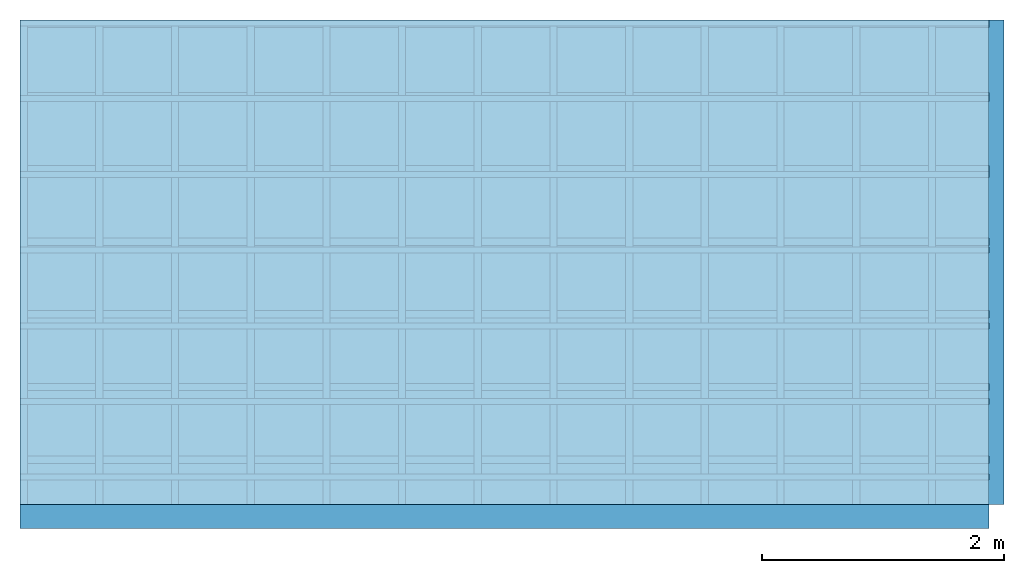
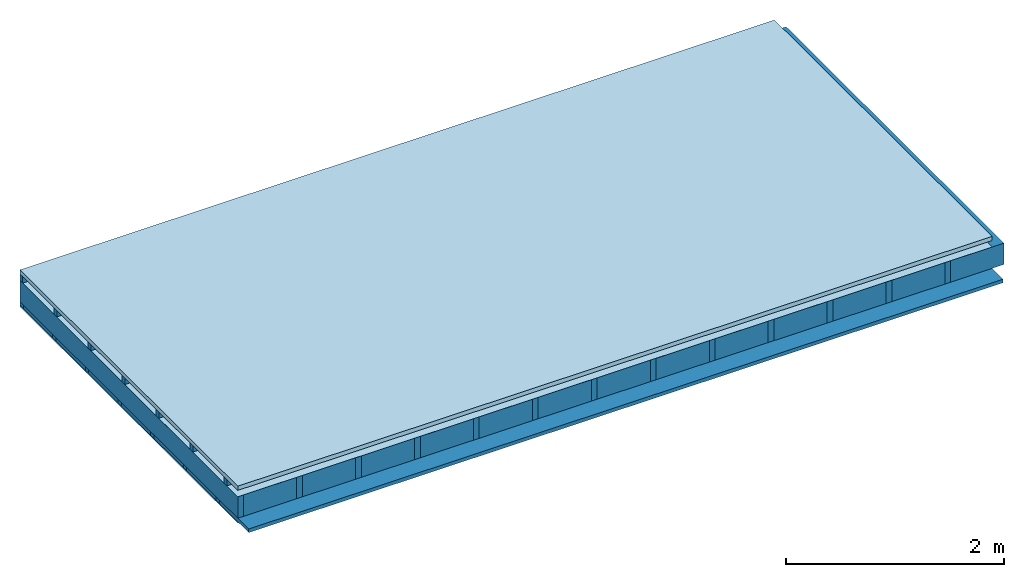
# One storey: 5 members, 3 plates, 1 element without a shape of its own.
"""IFC4 building model written with IfcOpenShell, lengths in metres."""

from ifc_helpers import new_model, si_unit, derived_unit, direction, frame, frame_2d, origin, origin_with_axes, place, context, project, spatial, rectangle, extrude, material, layer, layer_set, type_object, element, aggregate, save


model = new_model("IFC4")

# Units and contexts
plan_context = context("Plan", 3, precision=1e-05, world=origin(), true_north=direction((0.0, 1.0)))
model_context = context("Model", 3, precision=1e-05, world=origin(), true_north=direction((0.0, 1.0)))
ifc_project = project(units=[si_unit("LENGTHUNIT", "METRE"), derived_unit("SOUNDPRESSUREUNIT", [(si_unit("PRESSUREUNIT", "PASCAL", prefix="MICRO"), 0)]), si_unit("ENERGYUNIT", "JOULE", prefix="MEGA"), si_unit("MASSUNIT", "GRAM", prefix="KILO"), derived_unit("THERMALTRANSMITTANCEUNIT", [(si_unit("POWERUNIT", "WATT"), 1), (si_unit("AREAUNIT", "SQUARE_METRE"), -1), (si_unit("THERMODYNAMICTEMPERATUREUNIT", "KELVIN"), -1)]), derived_unit("AREADENSITYUNIT", [(si_unit("MASSUNIT", "GRAM", prefix="KILO"), 1), (si_unit("AREAUNIT", "SQUARE_METRE"), -1)]), derived_unit("USERDEFINED", [(si_unit("ENERGYUNIT", "JOULE", prefix="MEGA"), 1), (si_unit("AREAUNIT", "SQUARE_METRE"), -1)])], contexts=[plan_context, model_context])

# Site, building, storey
site = spatial("IfcSite", under=ifc_project)
building_placement = place(None, origin())
building = spatial("IfcBuilding", under=site, at=building_placement)
storey_placement = place(building_placement, origin())
storey = spatial("IfcBuildingStorey", under=building, at=storey_placement)

# Slab, members, plates
ifc_material_1 = material(Name="Roof tiles", Category="03.015")
ifc_layer_1 = layer(ifc_material_1, 0.047, Name="Roofing")
ifc_layer_2 = layer(None, 0.072, Name="Battens / profiles")
ifc_material_2 = material(Name="Roofing underlay", Category="09.008")
ifc_layer_3 = layer(ifc_material_2, 0.00018, Name="Under the roof")
ifc_material_3 = material(Name="no composite action")
ifc_layer_4 = layer(ifc_material_3, 0.0, Name="Bond")
ifc_layer_5 = layer(None, 0.24, Name="Supporting structure")
ifc_material_4 = material(Name="of the art")
ifc_layer_6 = layer(ifc_material_4, 0.0, Name="Bond")
ifc_layer_7 = layer(None, 0.04, Name="Battens / profiles")
ifc_material_5 = material(Name="Plasterboard type A", Category="03.008")
ifc_layer_8 = layer(ifc_material_5, 0.015, Name="Covering below 1st layer")
ifc_material_6 = material(Name="joints", Category="04.017")
ifc_layer_9 = layer(ifc_material_6, 0.0, Name="Surface below")
ifc_layer_set = layer_set([ifc_layer_1, ifc_layer_2, ifc_layer_3, ifc_layer_4, ifc_layer_5, ifc_layer_6, ifc_layer_7, ifc_layer_8, ifc_layer_9])
slab_type = type_object("IfcSlabType", Name="E0073", PredefinedType="NOTDEFINED", material=ifc_layer_set)
slab_placement = place(None, frame((0.0, 0.0, 0.0), z_axis=(0.0, 0.0, -1.0), x_axis=(1.0, 0.0, 0.0)))
slab = element("IfcSlab", 1, at=slab_placement, inside=storey, type_object=slab_type, material=ifc_layer_set, Name="Slab #1")
ifc_material_7 = material()
member_1_placement = place(slab_placement, origin())
member_1 = element("IfcMember", 2, at=member_1_placement, material=ifc_material_7, Name="Battens / profiles", context=plan_context, shape_type="SweptSolid", body=[
    extrude(rectangle(XDim=0.05, YDim=0.072, at=frame_2d((0.025, 0.036), x_axis=(1.0, 0.0))), frame((0.0, 0.0, 0.047), z_axis=(1.0, 0.0, 0.0), x_axis=(0.0, 1.0, 0.0)), (0.0, 0.0, 1.0), 8.0),
    extrude(rectangle(XDim=0.05, YDim=0.072, at=frame_2d((0.025, 0.036), x_axis=(1.0, 0.0))), frame((0.0, 0.625, 0.047), z_axis=(1.0, 0.0, 0.0), x_axis=(0.0, 1.0, 0.0)), (0.0, 0.0, 1.0), 8.0),
    extrude(rectangle(XDim=0.05, YDim=0.072, at=frame_2d((0.025, 0.036), x_axis=(1.0, 0.0))), frame((0.0, 1.25, 0.047), z_axis=(1.0, 0.0, 0.0), x_axis=(0.0, 1.0, 0.0)), (0.0, 0.0, 1.0), 8.0),
    extrude(rectangle(XDim=0.05, YDim=0.072, at=frame_2d((0.025, 0.036), x_axis=(1.0, 0.0))), frame((0.0, 1.875, 0.047), z_axis=(1.0, 0.0, 0.0), x_axis=(0.0, 1.0, 0.0)), (0.0, 0.0, 1.0), 8.0),
    extrude(rectangle(XDim=0.05, YDim=0.072, at=frame_2d((0.025, 0.036), x_axis=(1.0, 0.0))), frame((0.0, 2.5, 0.047), z_axis=(1.0, 0.0, 0.0), x_axis=(0.0, 1.0, 0.0)), (0.0, 0.0, 1.0), 8.0),
    extrude(rectangle(XDim=0.05, YDim=0.072, at=frame_2d((0.025, 0.036), x_axis=(1.0, 0.0))), frame((0.0, 3.125, 0.047), z_axis=(1.0, 0.0, 0.0), x_axis=(0.0, 1.0, 0.0)), (0.0, 0.0, 1.0), 8.0),
    extrude(rectangle(XDim=0.05, YDim=0.072, at=frame_2d((0.025, 0.036), x_axis=(1.0, 0.0))), frame((0.0, 3.75, 0.047), z_axis=(1.0, 0.0, 0.0), x_axis=(0.0, 1.0, 0.0)), (0.0, 0.0, 1.0), 8.0),
])
ifc_material_8 = material()
member_2_placement = place(slab_placement, origin())
member_2 = element("IfcMember", 3, at=member_2_placement, material=ifc_material_8, Name="Supporting structure", context=plan_context, shape_type="SweptSolid", body=[
    extrude(rectangle(XDim=0.06, YDim=0.24, at=frame_2d((0.03, 0.12), x_axis=(1.0, 0.0))), frame((0.0, 4.0, 0.11918), z_axis=(0.0, -1.0, 0.0), x_axis=(1.0, 0.0, 0.0)), (0.0, 0.0, 1.0), 4.0),
    extrude(rectangle(XDim=0.06, YDim=0.24, at=frame_2d((0.03, 0.12), x_axis=(1.0, 0.0))), frame((0.625, 4.0, 0.11918), z_axis=(0.0, -1.0, 0.0), x_axis=(1.0, 0.0, 0.0)), (0.0, 0.0, 1.0), 4.0),
    extrude(rectangle(XDim=0.06, YDim=0.24, at=frame_2d((0.03, 0.12), x_axis=(1.0, 0.0))), frame((1.25, 4.0, 0.11918), z_axis=(0.0, -1.0, 0.0), x_axis=(1.0, 0.0, 0.0)), (0.0, 0.0, 1.0), 4.0),
    extrude(rectangle(XDim=0.06, YDim=0.24, at=frame_2d((0.03, 0.12), x_axis=(1.0, 0.0))), frame((1.875, 4.0, 0.11918), z_axis=(0.0, -1.0, 0.0), x_axis=(1.0, 0.0, 0.0)), (0.0, 0.0, 1.0), 4.0),
    extrude(rectangle(XDim=0.06, YDim=0.24, at=frame_2d((0.03, 0.12), x_axis=(1.0, 0.0))), frame((2.5, 4.0, 0.11918), z_axis=(0.0, -1.0, 0.0), x_axis=(1.0, 0.0, 0.0)), (0.0, 0.0, 1.0), 4.0),
    extrude(rectangle(XDim=0.06, YDim=0.24, at=frame_2d((0.03, 0.12), x_axis=(1.0, 0.0))), frame((3.125, 4.0, 0.11918), z_axis=(0.0, -1.0, 0.0), x_axis=(1.0, 0.0, 0.0)), (0.0, 0.0, 1.0), 4.0),
    extrude(rectangle(XDim=0.06, YDim=0.24, at=frame_2d((0.03, 0.12), x_axis=(1.0, 0.0))), frame((3.75, 4.0, 0.11918), z_axis=(0.0, -1.0, 0.0), x_axis=(1.0, 0.0, 0.0)), (0.0, 0.0, 1.0), 4.0),
    extrude(rectangle(XDim=0.06, YDim=0.24, at=frame_2d((0.03, 0.12), x_axis=(1.0, 0.0))), frame((4.375, 4.0, 0.11918), z_axis=(0.0, -1.0, 0.0), x_axis=(1.0, 0.0, 0.0)), (0.0, 0.0, 1.0), 4.0),
    extrude(rectangle(XDim=0.06, YDim=0.24, at=frame_2d((0.03, 0.12), x_axis=(1.0, 0.0))), frame((5.0, 4.0, 0.11918), z_axis=(0.0, -1.0, 0.0), x_axis=(1.0, 0.0, 0.0)), (0.0, 0.0, 1.0), 4.0),
    extrude(rectangle(XDim=0.06, YDim=0.24, at=frame_2d((0.03, 0.12), x_axis=(1.0, 0.0))), frame((5.625, 4.0, 0.11918), z_axis=(0.0, -1.0, 0.0), x_axis=(1.0, 0.0, 0.0)), (0.0, 0.0, 1.0), 4.0),
    extrude(rectangle(XDim=0.06, YDim=0.24, at=frame_2d((0.03, 0.12), x_axis=(1.0, 0.0))), frame((6.25, 4.0, 0.11918), z_axis=(0.0, -1.0, 0.0), x_axis=(1.0, 0.0, 0.0)), (0.0, 0.0, 1.0), 4.0),
    extrude(rectangle(XDim=0.06, YDim=0.24, at=frame_2d((0.03, 0.12), x_axis=(1.0, 0.0))), frame((6.875, 4.0, 0.11918), z_axis=(0.0, -1.0, 0.0), x_axis=(1.0, 0.0, 0.0)), (0.0, 0.0, 1.0), 4.0),
    extrude(rectangle(XDim=0.06, YDim=0.24, at=frame_2d((0.03, 0.12), x_axis=(1.0, 0.0))), frame((7.5, 4.0, 0.11918), z_axis=(0.0, -1.0, 0.0), x_axis=(1.0, 0.0, 0.0)), (0.0, 0.0, 1.0), 4.0),
])
ifc_material_9 = material()
member_3_placement = place(slab_placement, origin())
member_3 = element("IfcMember", 4, at=member_3_placement, material=ifc_material_9, Name="Cavity", context=plan_context, shape_type="SweptSolid", body=[
    extrude(rectangle(XDim=0.565, YDim=0.24, at=frame_2d((0.2825, 0.12), x_axis=(1.0, 0.0))), frame((0.06, 4.0, 0.11918), z_axis=(0.0, -1.0, 0.0), x_axis=(1.0, 0.0, 0.0)), (0.0, 0.0, 1.0), 4.0),
    extrude(rectangle(XDim=0.565, YDim=0.24, at=frame_2d((0.2825, 0.12), x_axis=(1.0, 0.0))), frame((0.685, 4.0, 0.11918), z_axis=(0.0, -1.0, 0.0), x_axis=(1.0, 0.0, 0.0)), (0.0, 0.0, 1.0), 4.0),
    extrude(rectangle(XDim=0.565, YDim=0.24, at=frame_2d((0.2825, 0.12), x_axis=(1.0, 0.0))), frame((1.31, 4.0, 0.11918), z_axis=(0.0, -1.0, 0.0), x_axis=(1.0, 0.0, 0.0)), (0.0, 0.0, 1.0), 4.0),
    extrude(rectangle(XDim=0.565, YDim=0.24, at=frame_2d((0.2825, 0.12), x_axis=(1.0, 0.0))), frame((1.935, 4.0, 0.11918), z_axis=(0.0, -1.0, 0.0), x_axis=(1.0, 0.0, 0.0)), (0.0, 0.0, 1.0), 4.0),
    extrude(rectangle(XDim=0.565, YDim=0.24, at=frame_2d((0.2825, 0.12), x_axis=(1.0, 0.0))), frame((2.56, 4.0, 0.11918), z_axis=(0.0, -1.0, 0.0), x_axis=(1.0, 0.0, 0.0)), (0.0, 0.0, 1.0), 4.0),
    extrude(rectangle(XDim=0.565, YDim=0.24, at=frame_2d((0.2825, 0.12), x_axis=(1.0, 0.0))), frame((3.185, 4.0, 0.11918), z_axis=(0.0, -1.0, 0.0), x_axis=(1.0, 0.0, 0.0)), (0.0, 0.0, 1.0), 4.0),
    extrude(rectangle(XDim=0.565, YDim=0.24, at=frame_2d((0.2825, 0.12), x_axis=(1.0, 0.0))), frame((3.81, 4.0, 0.11918), z_axis=(0.0, -1.0, 0.0), x_axis=(1.0, 0.0, 0.0)), (0.0, 0.0, 1.0), 4.0),
    extrude(rectangle(XDim=0.565, YDim=0.24, at=frame_2d((0.2825, 0.12), x_axis=(1.0, 0.0))), frame((4.435, 4.0, 0.11918), z_axis=(0.0, -1.0, 0.0), x_axis=(1.0, 0.0, 0.0)), (0.0, 0.0, 1.0), 4.0),
    extrude(rectangle(XDim=0.565, YDim=0.24, at=frame_2d((0.2825, 0.12), x_axis=(1.0, 0.0))), frame((5.06, 4.0, 0.11918), z_axis=(0.0, -1.0, 0.0), x_axis=(1.0, 0.0, 0.0)), (0.0, 0.0, 1.0), 4.0),
    extrude(rectangle(XDim=0.565, YDim=0.24, at=frame_2d((0.2825, 0.12), x_axis=(1.0, 0.0))), frame((5.685, 4.0, 0.11918), z_axis=(0.0, -1.0, 0.0), x_axis=(1.0, 0.0, 0.0)), (0.0, 0.0, 1.0), 4.0),
    extrude(rectangle(XDim=0.565, YDim=0.24, at=frame_2d((0.2825, 0.12), x_axis=(1.0, 0.0))), frame((6.31, 4.0, 0.11918), z_axis=(0.0, -1.0, 0.0), x_axis=(1.0, 0.0, 0.0)), (0.0, 0.0, 1.0), 4.0),
    extrude(rectangle(XDim=0.565, YDim=0.24, at=frame_2d((0.2825, 0.12), x_axis=(1.0, 0.0))), frame((6.935, 4.0, 0.11918), z_axis=(0.0, -1.0, 0.0), x_axis=(1.0, 0.0, 0.0)), (0.0, 0.0, 1.0), 4.0),
    extrude(rectangle(XDim=0.565, YDim=0.24, at=frame_2d((0.2825, 0.12), x_axis=(1.0, 0.0))), frame((7.56, 4.0, 0.11918), z_axis=(0.0, -1.0, 0.0), x_axis=(1.0, 0.0, 0.0)), (0.0, 0.0, 1.0), 4.0),
])
ifc_material_10 = material()
member_4_placement = place(slab_placement, origin())
member_4 = element("IfcMember", 5, at=member_4_placement, material=ifc_material_10, Name="Battens / profiles", context=plan_context, shape_type="SweptSolid", body=[
    extrude(rectangle(XDim=0.06, YDim=0.04, at=frame_2d((0.03, 0.02), x_axis=(1.0, 0.0))), frame((0.0, 0.0, 0.35918), z_axis=(1.0, 0.0, 0.0), x_axis=(0.0, 1.0, 0.0)), (0.0, 0.0, 1.0), 8.0),
    extrude(rectangle(XDim=0.06, YDim=0.04, at=frame_2d((0.03, 0.02), x_axis=(1.0, 0.0))), frame((0.0, 0.6, 0.35918), z_axis=(1.0, 0.0, 0.0), x_axis=(0.0, 1.0, 0.0)), (0.0, 0.0, 1.0), 8.0),
    extrude(rectangle(XDim=0.06, YDim=0.04, at=frame_2d((0.03, 0.02), x_axis=(1.0, 0.0))), frame((0.0, 1.2, 0.35918), z_axis=(1.0, 0.0, 0.0), x_axis=(0.0, 1.0, 0.0)), (0.0, 0.0, 1.0), 8.0),
    extrude(rectangle(XDim=0.06, YDim=0.04, at=frame_2d((0.03, 0.02), x_axis=(1.0, 0.0))), frame((0.0, 1.8, 0.35918), z_axis=(1.0, 0.0, 0.0), x_axis=(0.0, 1.0, 0.0)), (0.0, 0.0, 1.0), 8.0),
    extrude(rectangle(XDim=0.06, YDim=0.04, at=frame_2d((0.03, 0.02), x_axis=(1.0, 0.0))), frame((0.0, 2.4, 0.35918), z_axis=(1.0, 0.0, 0.0), x_axis=(0.0, 1.0, 0.0)), (0.0, 0.0, 1.0), 8.0),
    extrude(rectangle(XDim=0.06, YDim=0.04, at=frame_2d((0.03, 0.02), x_axis=(1.0, 0.0))), frame((0.0, 3.0, 0.35918), z_axis=(1.0, 0.0, 0.0), x_axis=(0.0, 1.0, 0.0)), (0.0, 0.0, 1.0), 8.0),
    extrude(rectangle(XDim=0.06, YDim=0.04, at=frame_2d((0.03, 0.02), x_axis=(1.0, 0.0))), frame((0.0, 3.6, 0.35918), z_axis=(1.0, 0.0, 0.0), x_axis=(0.0, 1.0, 0.0)), (0.0, 0.0, 1.0), 8.0),
])
ifc_material_11 = material(Name="Mineral wool")
member_5_placement = place(slab_placement, origin())
member_5 = element("IfcMember", 6, at=member_5_placement, material=ifc_material_11, Name="Cavity", context=plan_context, shape_type="SweptSolid", body=[
    extrude(rectangle(XDim=0.54, YDim=0.04, at=frame_2d((0.27, 0.02), x_axis=(1.0, 0.0))), frame((0.0, 0.06, 0.35918), z_axis=(1.0, 0.0, 0.0), x_axis=(0.0, 1.0, 0.0)), (0.0, 0.0, 1.0), 8.0),
    extrude(rectangle(XDim=0.54, YDim=0.04, at=frame_2d((0.27, 0.02), x_axis=(1.0, 0.0))), frame((0.0, 0.66, 0.35918), z_axis=(1.0, 0.0, 0.0), x_axis=(0.0, 1.0, 0.0)), (0.0, 0.0, 1.0), 8.0),
    extrude(rectangle(XDim=0.54, YDim=0.04, at=frame_2d((0.27, 0.02), x_axis=(1.0, 0.0))), frame((0.0, 1.26, 0.35918), z_axis=(1.0, 0.0, 0.0), x_axis=(0.0, 1.0, 0.0)), (0.0, 0.0, 1.0), 8.0),
    extrude(rectangle(XDim=0.54, YDim=0.04, at=frame_2d((0.27, 0.02), x_axis=(1.0, 0.0))), frame((0.0, 1.86, 0.35918), z_axis=(1.0, 0.0, 0.0), x_axis=(0.0, 1.0, 0.0)), (0.0, 0.0, 1.0), 8.0),
    extrude(rectangle(XDim=0.54, YDim=0.04, at=frame_2d((0.27, 0.02), x_axis=(1.0, 0.0))), frame((0.0, 2.46, 0.35918), z_axis=(1.0, 0.0, 0.0), x_axis=(0.0, 1.0, 0.0)), (0.0, 0.0, 1.0), 8.0),
    extrude(rectangle(XDim=0.54, YDim=0.04, at=frame_2d((0.27, 0.02), x_axis=(1.0, 0.0))), frame((0.0, 3.06, 0.35918), z_axis=(1.0, 0.0, 0.0), x_axis=(0.0, 1.0, 0.0)), (0.0, 0.0, 1.0), 8.0),
    extrude(rectangle(XDim=0.54, YDim=0.04, at=frame_2d((0.27, 0.02), x_axis=(1.0, 0.0))), frame((0.0, 3.66, 0.35918), z_axis=(1.0, 0.0, 0.0), x_axis=(0.0, 1.0, 0.0)), (0.0, 0.0, 1.0), 8.0),
])
plate_1_placement = place(slab_placement, origin())
plate_1 = element("IfcPlate", 7, at=plate_1_placement, material=ifc_material_1, Name="Roofing", context=plan_context, shape_type="SweptSolid", body=[
    extrude(rectangle(XDim=8.0, YDim=4.0, at=frame_2d((4.0, 2.0), x_axis=(1.0, 0.0))), origin_with_axes(), (0.0, 0.0, 1.0), 0.047),
])
plate_2_placement = place(slab_placement, origin())
plate_2 = element("IfcPlate", 8, at=plate_2_placement, material=ifc_material_2, Name="Under the roof", context=plan_context, shape_type="SweptSolid", body=[
    extrude(rectangle(XDim=8.0, YDim=4.0, at=frame_2d((4.0, 2.0), x_axis=(1.0, 0.0))), frame((0.0, 0.0, 0.119), z_axis=(0.0, 0.0, 1.0), x_axis=(1.0, 0.0, 0.0)), (0.0, 0.0, 1.0), 0.00018),
])
plate_3_placement = place(slab_placement, origin())
plate_3 = element("IfcPlate", 9, at=plate_3_placement, material=ifc_material_5, Name="Covering below 1st layer", context=plan_context, shape_type="SweptSolid", body=[
    extrude(rectangle(XDim=8.0, YDim=4.0, at=frame_2d((4.0, 2.0), x_axis=(1.0, 0.0))), frame((0.0, 0.0, 0.39918), z_axis=(0.0, 0.0, 1.0), x_axis=(1.0, 0.0, 0.0)), (0.0, 0.0, 1.0), 0.015),
])
aggregate(slab, [plate_1, member_1, plate_2, member_2, member_3, member_4, member_5, plate_3])

save(model, "model.ifc")
